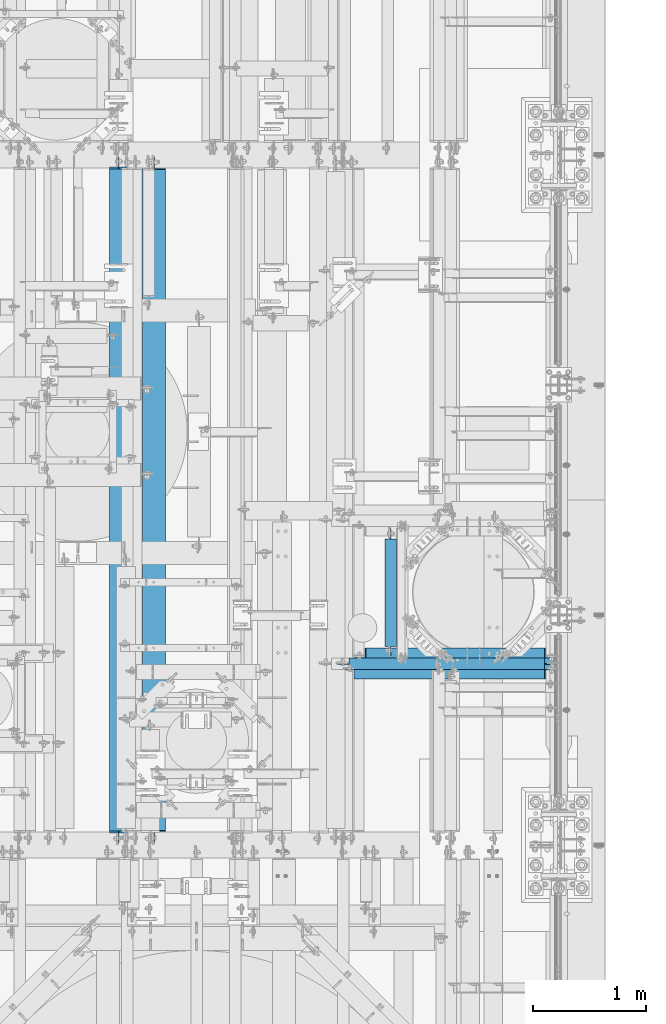
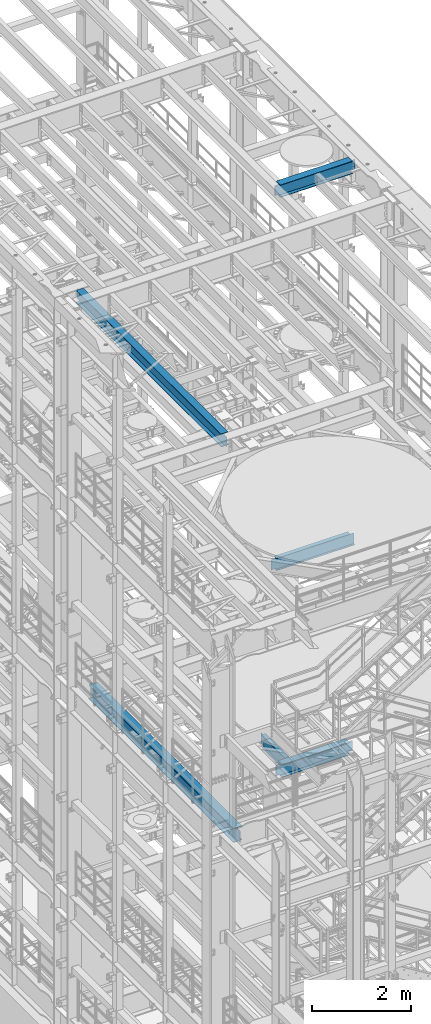
# One storey, part 1029 of 1876: 6 beams, 6 elements without a shape of their own.
"""IFC2X3 building model written with IfcOpenShell, lengths in millimetres."""

from ifc_helpers import new_model, si_unit, frame, origin_with_axes, place, context, subcontext, project, spatial, faceted_brep, material, type_object, element, aggregate, save


model = new_model("IFC2X3")

# Units and contexts
model_context = context("Model", 3, precision=1e-05, world=origin_with_axes())
body_context = subcontext(model_context, "Body", "Model", "MODEL_VIEW")
ifc_project = project(units=[si_unit("LENGTHUNIT", "METRE", prefix="MILLI"), si_unit("AREAUNIT", "SQUARE_METRE"), si_unit("VOLUMEUNIT", "CUBIC_METRE"), si_unit("MASSUNIT", "GRAM", prefix="KILO"), si_unit("TIMEUNIT", "SECOND"), si_unit("PLANEANGLEUNIT", "RADIAN"), si_unit("SOLIDANGLEUNIT", "STERADIAN"), si_unit("THERMODYNAMICTEMPERATUREUNIT", "DEGREE_CELSIUS"), si_unit("LUMINOUSINTENSITYUNIT", "LUMEN")], contexts=[model_context])

# Site, building, storey
site_placement = place(None, origin_with_axes())
site = spatial("IfcSite", under=ifc_project, at=site_placement, CompositionType="ELEMENT")
building_placement = place(site_placement, origin_with_axes())
building = spatial("IfcBuilding", under=site, at=building_placement, Name="Undefined", CompositionType="ELEMENT")
storey_placement = place(building_placement, origin_with_axes())
storey = spatial("IfcBuildingStorey", under=building, at=storey_placement, Name="Undefined", CompositionType="ELEMENT", Elevation=0.0)

# Assembly, beam
assembly_1_placement = place(storey_placement, origin_with_axes())
assembly_1 = element("IfcElementAssembly", 1, at=assembly_1_placement, inside=storey, Name="BEAM", AssemblyPlace="NOTDEFINED", PredefinedType="RIGID_FRAME")
ifc_material = material(Name="STEEL/A992")
beam_type_1 = type_object("IfcBeamType", Name="W12X26", PredefinedType="NOTDEFINED")
beam_1_placement = place(assembly_1_placement, frame((5715.0, 3073.39920043945, 22399.625), z_axis=(0.0, 0.0, 1.0), x_axis=(1.0, 0.0, 0.0)))
beam_1 = element("IfcBeam", 2, at=beam_1_placement, type_object=beam_type_1, material=ifc_material, Name="BEAM", ObjectType="W12X26", context=body_context, shape_type="Brep", body=[
    faceted_brep([(1789.90625, -3.17500000000018, -146.049999999999), (1789.90625, -82.5500000000002, -146.049999999999), (1789.90625, -82.5500000000002, -155.575000000001), (1789.90625, 82.5500000000002, -155.575000000001), (1789.90625, 82.5500000000002, -146.049999999999), (1789.90625, 3.17500000000018, -146.049999999999), (1789.90625, 3.17500000000018, -142.874999809264), (1789.90625, -3.17500000000018, -142.874999809264), (1790.87297992259, 3.17500000000018, -138.014920291218), (1790.87297992259, -3.17500000000018, -138.014920291218), (1793.62599382307, 3.17500000000018, -133.894743823064), (1793.62599382307, -3.17500000000018, -133.894743823064), (1797.74617029122, 3.17500000000018, -131.141729922587), (1797.74617029122, -3.17500000000018, -131.141729922587), (1802.60624980926, 3.17500000000018, -130.174999999999), (1802.60624980926, -3.17500000000018, -130.174999999999), (1885.15625, -3.17500000000018, -130.174999999999), (1885.15625, 3.17500000000018, -130.174999999999), (98.4250000000029, 3.17500000000018, 146.049999999999), (98.4250000000002, 82.5500000000002, 146.049999999999), (1777.20625, 82.5500000000002, 146.049999999999), (1777.20625, 3.17500000000018, 146.049999999999), (98.4250000000002, -3.17500000000018, -142.874999809268), (98.4250000000002, 3.17500000000018, -142.874999809268), (98.4250000000029, 3.17500000000018, -146.049999999999), (98.4250000000002, 82.5500000000002, -146.049999999999), (98.4250000000002, 82.5500000000002, -155.575000000001), (98.4250000000002, -82.5500000000002, -155.575000000001), (98.4250000000002, -82.5500000000002, -146.049999999999), (98.4250000000029, -3.17500000000018, -146.049999999999), (97.4582700774126, -3.17500000000018, -138.014920291222), (97.4582700774126, 3.17500000000018, -138.014920291222), (94.7052561769342, -3.17500000000018, -133.894743823068), (94.7052561769342, 3.17500000000018, -133.894743823068), (90.5850797087805, -3.17500000000018, -131.14172992259), (90.5850797087805, 3.17500000000018, -131.14172992259), (85.725000190735, -3.17500000000018, -130.175000000003), (85.725000190735, 3.17500000000018, -130.175000000003), (15.875, -3.17500000000018, -130.175000000003), (15.875, 3.17500000000018, -130.175000000003), (15.875, -3.17500000000018, 117.474999999999), (15.875, 3.17500000000018, 117.474999999999), (85.725000190735, -3.17500000000018, 117.474999999999), (85.725000190735, 3.17500000000018, 117.474999999999), (90.5850797087805, -3.17500000000018, 118.441729922586), (90.5850797087805, 3.17500000000018, 118.441729922586), (94.7052561769342, -3.17500000000018, 121.194743823064), (94.7052561769342, 3.17500000000018, 121.194743823064), (97.4582700774126, -3.17500000000018, 125.314920291217), (97.4582700774126, 3.17500000000018, 125.314920291217), (98.4250000000002, -3.17500000000018, 130.174999809264), (98.4250000000002, 3.17500000000018, 130.174999809264), (98.4250000000002, -82.5500000000002, 155.575000000001), (98.4250000000002, 82.5500000000002, 155.575000000001), (98.4250000000029, -3.17500000000018, 146.049999999999), (98.4250000000002, -82.5500000000002, 146.049999999999), (1777.20625, -3.17500000000018, 146.049999999999), (1777.20625, -82.5500000000002, 146.049999999999), (1777.20625, -82.5500000000002, 155.575000000001), (1777.20625, 82.5500000000002, 155.575000000001), (1777.20625, -3.17500000000018, 130.174999809267), (1777.20625, 3.17500000000018, 130.174999809267), (1778.17297992259, -3.17500000000018, 125.314920291221), (1778.17297992259, 3.17500000000018, 125.314920291221), (1780.92599382307, -3.17500000000018, 121.194743823067), (1780.92599382307, 3.17500000000018, 121.194743823067), (1785.04617029122, -3.17500000000018, 118.44172992259), (1785.04617029122, 3.17500000000018, 118.44172992259), (1789.90624980926, -3.17500000000018, 117.475000000002), (1789.90624980926, 3.17500000000018, 117.475000000002), (1885.15625, -3.17500000000018, 117.475000000002), (1885.15625, 3.17500000000018, 117.475000000002)], [[[0, 1, 2, 3, 4, 5, 6, 7]], [[7, 6, 8, 9]], [[9, 8, 10, 11]], [[11, 10, 12, 13]], [[13, 12, 14, 15]], [[16, 15, 14, 17]], [[18, 19, 20, 21]], [[22, 23, 24, 25, 26, 27, 28, 29]], [[30, 31, 23, 22]], [[32, 33, 31, 30]], [[34, 35, 33, 32]], [[36, 37, 35, 34]], [[38, 39, 37, 36]], [[40, 41, 39, 38]], [[42, 43, 41, 40]], [[44, 45, 43, 42]], [[46, 47, 45, 44]], [[48, 49, 47, 46]], [[50, 51, 49, 48]], [[52, 53, 19, 18, 51, 50, 54, 55]], [[55, 54, 56, 57]], [[52, 55, 57, 58]], [[53, 52, 58, 59]], [[19, 53, 59, 20]], [[58, 57, 56, 60, 61, 21, 20, 59]], [[62, 63, 61, 60]], [[64, 65, 63, 62]], [[66, 67, 65, 64]], [[68, 69, 67, 66]], [[70, 71, 69, 68]], [[71, 70, 16, 17]], [[12, 10, 8, 6, 5, 24, 23, 31, 33, 35, 37, 39, 41, 43, 45, 47, 49, 51, 18, 21, 61, 63, 65, 67, 69, 71, 17, 14]], [[25, 24, 5, 4]], [[26, 25, 4, 3]], [[27, 26, 3, 2]], [[28, 27, 2, 1]], [[29, 28, 1, 0]], [[70, 68, 66, 64, 62, 60, 56, 54, 50, 48, 46, 44, 42, 40, 38, 36, 34, 32, 30, 22, 29, 0, 7, 9, 11, 13, 15, 16]]]),
])
aggregate(assembly_1, [beam_1])

assembly_2_placement = place(storey_placement, origin_with_axes())
assembly_2 = element("IfcElementAssembly", 3, at=assembly_2_placement, inside=storey, Name="BEAM", AssemblyPlace="NOTDEFINED", PredefinedType="RIGID_FRAME")
beam_2_placement = place(assembly_2_placement, frame((3733.8, 1524.0, 17827.625), z_axis=(0.0, 0.0, 1.0), x_axis=(0.0, 1.0, 0.0)))
beam_2 = element("IfcBeam", 4, at=beam_2_placement, type_object=beam_type_1, material=ifc_material, Name="BEAM", ObjectType="W12X26", context=body_context, shape_type="Brep", body=[
    faceted_brep([(19.8437512414296, -3.17500000000109, -130.175), (19.8437487585795, 3.17499999999927, -130.175), (96.0437824675421, 3.175000000002, -130.175), (96.0437824675423, -3.17499999999745, -130.175), (100.903861985588, 3.175000000002, -131.141729922588), (100.903861985589, -3.17499999999745, -131.141729922588), (105.024038453743, 3.17500000000291, -133.894743823066), (105.024038453744, -3.17499999999654, -133.894743823066), (107.777052354222, 3.17500000000291, -138.01492029122), (107.777052354222, -3.17499999999745, -138.01492029122), (108.743782276811, -3.17499999999654, -142.874999809265), (108.74378227681, 3.17500000000291, -142.874999809265), (108.74375, 3.17500009516311, -146.049999999999), (108.743782276807, 82.5500000000084, -146.05), (108.743782276807, 82.5500000000084, -155.575), (108.743782276814, -82.5500000000029, -155.575), (108.743782276814, -82.5500000000029, -146.05), (108.74375, -3.17499999999995, -146.049999999999), (5969.79375, 82.55, 146.049999999999), (5969.79375, 3.17499999999995, 146.049999999999), (126.20625, 3.17499999999995, 146.049999999999), (126.20625, 82.55, 146.049999999999), (113.506250190735, -3.17499999999995, 111.125000000004), (113.506250190735, 3.17499998562812, 111.125000000004), (19.8437500000002, 3.17499999999995, 111.125000000004), (19.8437500000002, -3.17499999999995, 111.125000000004), (118.36632970878, -3.17499999999995, 112.091729922591), (118.36632970878, 3.17499998547237, 112.091729922591), (122.486506176934, -3.17499999999995, 114.844743823069), (122.486506176934, 3.17499998502694, 114.844743823069), (125.239520077412, -3.17499999999995, 118.964920291222), (125.239520077412, 3.17499998436006, 118.964920291222), (126.20625, -3.17499999999995, 123.824999809269), (126.20625, 3.17499998357312, 123.824999809269), (5969.79375, -82.55, 155.575000000001), (5969.79375, 82.55, 155.575000000001), (126.20625, 82.55, 155.575000000001), (126.20625, -82.55, 155.575000000001), (5969.79375, -82.55, 146.049999999999), (126.20625, -82.55, 146.049999999999), (5969.79375, -3.17499999999995, 146.049999999999), (126.20625, -3.17499999999995, 146.049999999999), (5969.79375, -3.17499999999995, 123.824999809269), (5969.79375, 3.17499999999995, 123.824999809269), (5970.76047992259, -3.17499999999995, 118.964920291222), (5970.76047992259, 3.17499999999995, 118.964920291222), (5973.51349382307, -3.17499999999995, 114.844743823069), (5973.51349382307, 3.17499999999995, 114.844743823069), (5977.63367029122, -3.17499999999995, 112.091729922591), (5977.63367029122, 3.17499999999995, 112.091729922591), (5982.49374980926, -3.17499999999995, 111.125000000004), (5982.49374980926, 3.17499999999995, 111.125000000004), (6076.15625, -3.17499999999995, 111.125000000004), (6076.15625, 3.17499999999995, 111.125000000004), (6076.15625, -3.17499999999995, -130.174999999996), (6076.15625, 3.17499999999995, -130.174999999996), (5999.95624980927, -3.17499999999995, -130.174999999996), (5999.95624980927, 3.17499999999995, -130.174999999996), (5995.09617029122, -3.17499999999995, -131.141729922583), (5995.09617029122, 3.17499999999995, -131.141729922583), (5990.97599382307, -3.17499999999995, -133.894743823061), (5990.97599382307, 3.17499999999995, -133.894743823061), (5988.22297992259, -3.17499999999995, -138.014920291214), (5988.22297992259, 3.17499999999995, -138.014920291214), (5987.25625, -3.17499999999995, -142.874999809261), (5987.25625, 3.17499999999995, -142.874999809261), (5987.25625, -3.17499999999995, -146.049999999999), (5987.25625, -82.55, -146.049999999999), (5987.25625, -82.55, -155.575000000001), (5987.25625, 82.55, -155.575000000001), (5987.25625, 82.55, -146.049999999999), (5987.25625, 3.17499999999995, -146.049999999999)], [[[0, 1, 2, 3]], [[3, 2, 4, 5]], [[5, 4, 6, 7]], [[7, 6, 8, 9]], [[10, 11, 12, 13, 14, 15, 16, 17]], [[9, 8, 11, 10]], [[18, 19, 20, 21]], [[22, 23, 24, 25]], [[26, 27, 23, 22]], [[28, 29, 27, 26]], [[30, 31, 29, 28]], [[32, 33, 31, 30]], [[34, 35, 36, 37]], [[38, 34, 37, 39]], [[40, 38, 39, 41]], [[37, 36, 21, 20, 33, 32, 41, 39]], [[35, 18, 21, 36]], [[34, 38, 40, 42, 43, 19, 18, 35]], [[44, 45, 43, 42]], [[46, 47, 45, 44]], [[48, 49, 47, 46]], [[50, 51, 49, 48]], [[52, 53, 51, 50]], [[53, 52, 54, 55]], [[54, 56, 57, 55]], [[58, 59, 57, 56]], [[60, 61, 59, 58]], [[62, 63, 61, 60]], [[64, 65, 63, 62]], [[66, 67, 68, 69, 70, 71, 65, 64]], [[67, 66, 17, 16]], [[68, 67, 16, 15]], [[69, 68, 15, 14]], [[70, 69, 14, 13]], [[71, 70, 13, 12]], [[6, 4, 2, 1, 24, 23, 27, 29, 31, 33, 20, 19, 43, 45, 47, 49, 51, 53, 55, 57, 59, 61, 63, 65, 71, 12, 11, 8]], [[25, 24, 1, 0]], [[66, 64, 62, 60, 58, 56, 54, 52, 50, 48, 46, 44, 42, 40, 41, 32, 30, 28, 26, 22, 25, 0, 3, 5, 7, 9, 10, 17]]]),
])
aggregate(assembly_2, [beam_2])

assembly_3_placement = place(storey_placement, origin_with_axes())
assembly_3 = element("IfcElementAssembly", 5, at=assembly_3_placement, inside=storey, Name="BEAM", AssemblyPlace="NOTDEFINED", PredefinedType="RIGID_FRAME")
beam_type_2 = type_object("IfcBeamType", Name="W12X16", PredefinedType="NOTDEFINED")
beam_3_placement = place(assembly_3_placement, frame((5651.5, 3124.2, 13157.2), z_axis=(0.0, 0.0, 1.0), x_axis=(1.0, 0.0, 0.0)))
beam_3 = element("IfcBeam", 6, at=beam_3_placement, type_object=beam_type_2, material=ifc_material, Name="BEAM", ObjectType="W12X16", context=body_context, shape_type="Brep", body=[
    faceted_brep([(1840.70625305176, -50.8000000000002, 152.4), (1840.70625305176, -50.8000000000002, 146.049999999999), (1840.70625305176, -3.17500000000018, 146.049999999999), (1840.70625305176, -3.17500000000018, 126.999999809264), (1840.70625305176, 3.17500000000018, 126.999999809264), (1840.70625305176, 3.17500000000018, 146.049999999999), (1840.70625305176, 50.8000000000002, 146.049999999999), (1840.70625305176, 50.8000000000002, 152.4), (1841.67298297434, -3.17500000000018, 122.139920291218), (1841.67298297434, 3.17500000000018, 122.139920291218), (1844.42599687482, -3.17500000000018, 118.019743823064), (1844.42599687482, 3.17500000000018, 118.019743823064), (1848.54617334297, -3.17500000000018, 115.266729922587), (1848.54617334297, 3.17500000000018, 115.266729922587), (1853.40625286102, -3.17500000000018, 114.299999999999), (1853.40625286102, 3.17500000000018, 114.299999999999), (1948.65625, -3.17500000000018, 114.299999999999), (1948.65625, 3.17500000000018, 114.299999999999), (117.475, -50.8000000000002, 152.4), (117.475, 50.8000000000002, 152.4), (117.475, 50.8000000000002, 146.049999999999), (117.475, 3.17500000000018, 146.049999999999), (117.475, 3.17500000000018, 139.699999809265), (117.475, -3.17500000000018, 139.699999809265), (117.475, -3.17500000000018, 146.049999999999), (117.475, -50.8000000000002, 146.049999999999), (116.508270077413, 3.17500000000018, 134.839920291219), (116.508270077413, -3.17500000000018, 134.839920291219), (113.755256176934, 3.17500000000018, 130.719743823065), (113.755256176934, -3.17500000000018, 130.719743823065), (109.635079708781, 3.17500000000018, 127.966729922588), (109.635079708781, -3.17500000000018, 127.966729922588), (104.775000190735, 3.17500000000018, 127.0), (104.775000190735, -3.17500000000018, 127.0), (15.875, 3.17500000000018, 127.000000000001), (15.875, -3.17500000000018, 127.000000000001), (15.8749999999982, 3.17500000000018, -127.0), (15.8749999999982, -3.17500000000018, -127.0), (104.775000190735, 3.17500000000018, -127.0), (104.775000190735, -3.17500000000018, -127.0), (109.635079708781, 3.17500000000018, -127.966729922588), (109.635079708781, -3.17500000000018, -127.966729922588), (113.755256176934, 3.17500000000018, -130.719743823065), (113.755256176934, -3.17500000000018, -130.719743823065), (116.508270077413, 3.17500000000018, -134.839920291219), (116.508270077413, -3.17500000000018, -134.839920291219), (117.475, 3.17500000000018, -139.699999809265), (117.475, -3.17500000000018, -139.699999809265), (1948.65625, 3.17500000000018, -146.049999999999), (1948.65625, 50.8000000000002, -146.049999999999), (117.475, 50.8000000000002, -146.049999999999), (117.475, 3.17500000000018, -146.049999999999), (1948.65625, 50.8000000000002, -152.4), (117.475, 50.8000000000002, -152.4), (1948.65625, -50.8000000000002, -152.4), (117.475, -50.8000000000002, -152.4), (1948.65625, -50.8000000000002, -146.049999999999), (117.475, -50.8000000000002, -146.049999999999), (117.475, -3.17500000000018, -146.049999999999), (1948.65625, -3.17500000000018, -146.049999999999)], [[[0, 1, 2, 3, 4, 5, 6, 7]], [[8, 9, 4, 3]], [[10, 11, 9, 8]], [[12, 13, 11, 10]], [[14, 15, 13, 12]], [[16, 17, 15, 14]], [[18, 19, 20, 21, 22, 23, 24, 25]], [[23, 22, 26, 27]], [[27, 26, 28, 29]], [[29, 28, 30, 31]], [[31, 30, 32, 33]], [[33, 32, 34, 35]], [[35, 34, 36, 37]], [[37, 36, 38, 39]], [[39, 38, 40, 41]], [[41, 40, 42, 43]], [[43, 42, 44, 45]], [[45, 44, 46, 47]], [[48, 49, 50, 51]], [[49, 52, 53, 50]], [[52, 54, 55, 53]], [[54, 56, 57, 55]], [[47, 46, 51, 50, 53, 55, 57, 58]], [[56, 59, 58, 57]], [[12, 10, 8, 3, 2, 24, 23, 27, 29, 31, 33, 35, 37, 39, 41, 43, 45, 47, 58, 59, 16, 14]], [[25, 24, 2, 1]], [[18, 25, 1, 0]], [[19, 18, 0, 7]], [[20, 19, 7, 6]], [[21, 20, 6, 5]], [[48, 51, 46, 44, 42, 40, 38, 36, 34, 32, 30, 28, 26, 22, 21, 5, 4, 9, 11, 13, 15, 17]], [[59, 56, 54, 52, 49, 48, 17, 16]]]),
])
aggregate(assembly_3, [beam_3])

assembly_4_placement = place(storey_placement, origin_with_axes())
assembly_4 = element("IfcElementAssembly", 7, at=assembly_4_placement, inside=storey, Name="BEAM", AssemblyPlace="NOTDEFINED", PredefinedType="RIGID_FRAME")
beam_4_placement = place(assembly_4_placement, frame((6134.1, 3181.35, 8001.0), z_axis=(0.0, 0.0, 1.0), x_axis=(0.0, 1.0, 0.0)))
beam_4 = element("IfcBeam", 8, at=beam_4_placement, type_object=beam_type_2, material=ifc_material, Name="BEAM", ObjectType="W12X16", context=body_context, shape_type="Brep", body=[
    faceted_brep([(17.4625000000005, -3.17500000000018, -126.999999999999), (17.4625000000005, 3.17500000000018, -126.999999999999), (100.012500190734, 3.17500000000018, -126.999999999999), (100.012500190734, -3.17500000000018, -126.999999999999), (104.87257970878, 3.17500000000018, -127.966729922587), (104.87257970878, -3.17500000000018, -127.966729922587), (108.992756176934, 3.17500000000018, -130.719743823065), (108.992756176934, -3.17500000000018, -130.719743823065), (111.745770077412, 3.17500000000018, -134.839920291219), (111.745770077412, -3.17500000000018, -134.839920291219), (112.7125, -3.17500000000018, -139.699999809264), (112.7125, 3.17500000000018, -139.699999809264), (112.712500000001, 3.17500000000018, -146.049999999999), (112.7125, 50.8000000000002, -146.05), (112.7125, 50.8000000000002, -152.4), (112.7125, -50.8000000000002, -152.4), (112.7125, -50.8000000000002, -146.05), (112.712500000001, -3.17500000000018, -146.049999999999), (1044.575, 50.8000000000002, 146.05), (1044.575, 3.17500000000018, 146.05), (96.8374999999996, 3.17500000000018, 146.05), (96.8374999999996, 50.8000000000002, 146.05), (84.1375001907345, -3.17500000000018, 127.000000000001), (84.1375001907345, 3.17500000000018, 127.000000000001), (17.4625000000005, 3.17500000000018, 127.000000000001), (17.4625000000005, -3.17500000000018, 127.000000000001), (88.99757970878, -3.17500000000018, 127.966729922588), (88.99757970878, 3.17500000000018, 127.966729922588), (93.1177561769337, -3.17500000000018, 130.719743823067), (93.1177561769337, 3.17500000000018, 130.719743823067), (95.8707700774116, -3.17500000000018, 134.839920291221), (95.8707700774116, 3.17500000000018, 134.839920291221), (96.8374999999996, -3.17500000000018, 139.699999809266), (96.8374999999996, 3.17500000000018, 139.699999809266), (1044.575, -50.8000000000002, 152.4), (1044.575, 50.8000000000002, 152.4), (96.8374999999996, 50.8000000000002, 152.4), (96.8374999999996, -50.8000000000002, 152.4), (1044.575, -50.8000000000002, 146.05), (96.8374999999996, -50.8000000000002, 146.05), (1044.575, -3.17500000000018, 146.05), (96.8374999999996, -3.17500000000018, 146.05), (1044.575, -3.17500000000018, 139.699999809266), (1044.575, 3.17500000000018, 139.699999809266), (1045.54172992259, -3.17500000000018, 134.839920291221), (1045.54172992259, 3.17500000000018, 134.839920291221), (1048.29474382306, -3.17500000000018, 130.719743823067), (1048.29474382306, 3.17500000000018, 130.719743823067), (1052.41492029122, -3.17500000000018, 127.966729922588), (1052.41492029122, 3.17500000000018, 127.966729922588), (1057.27499980926, -3.17500000000018, 127.000000000001), (1057.27499980926, 3.17500000000018, 127.000000000001), (1139.825, -3.17500000000018, 127.000000000001), (1139.825, 3.17500000000018, 127.000000000001), (1139.825, -3.17500000000018, -126.999999999999), (1139.825, 3.17500000000018, -126.999999999999), (1057.27499980926, -3.17500000000018, -126.999999999999), (1057.27499980926, 3.17500000000018, -126.999999999999), (1052.41492029122, -3.17500000000018, -127.966729922587), (1052.41492029122, 3.17500000000018, -127.966729922587), (1048.29474382306, -3.17500000000018, -130.719743823065), (1048.29474382306, 3.17500000000018, -130.719743823065), (1045.54172992259, -3.17500000000018, -134.839920291219), (1045.54172992259, 3.17500000000018, -134.839920291219), (1044.575, -3.17500000000018, -139.699999809264), (1044.575, 3.17500000000018, -139.699999809264), (1044.575, -3.17500000000018, -146.05), (1044.575, -50.8000000000002, -146.05), (1044.575, -50.8000000000002, -152.4), (1044.575, 50.8000000000002, -152.4), (1044.575, 50.8000000000002, -146.05), (1044.575, 3.17500000000018, -146.05)], [[[0, 1, 2, 3]], [[3, 2, 4, 5]], [[5, 4, 6, 7]], [[7, 6, 8, 9]], [[10, 11, 12, 13, 14, 15, 16, 17]], [[9, 8, 11, 10]], [[18, 19, 20, 21]], [[22, 23, 24, 25]], [[26, 27, 23, 22]], [[28, 29, 27, 26]], [[30, 31, 29, 28]], [[32, 33, 31, 30]], [[34, 35, 36, 37]], [[38, 34, 37, 39]], [[40, 38, 39, 41]], [[37, 36, 21, 20, 33, 32, 41, 39]], [[35, 18, 21, 36]], [[34, 38, 40, 42, 43, 19, 18, 35]], [[44, 45, 43, 42]], [[46, 47, 45, 44]], [[48, 49, 47, 46]], [[50, 51, 49, 48]], [[52, 53, 51, 50]], [[53, 52, 54, 55]], [[54, 56, 57, 55]], [[58, 59, 57, 56]], [[60, 61, 59, 58]], [[62, 63, 61, 60]], [[64, 65, 63, 62]], [[66, 67, 68, 69, 70, 71, 65, 64]], [[67, 66, 17, 16]], [[68, 67, 16, 15]], [[69, 68, 15, 14]], [[70, 69, 14, 13]], [[71, 70, 13, 12]], [[6, 4, 2, 1, 24, 23, 27, 29, 31, 33, 20, 19, 43, 45, 47, 49, 51, 53, 55, 57, 59, 61, 63, 65, 71, 12, 11, 8]], [[25, 24, 1, 0]], [[66, 64, 62, 60, 58, 56, 54, 52, 50, 48, 46, 44, 42, 40, 41, 32, 30, 28, 26, 22, 25, 0, 3, 5, 7, 9, 10, 17]]]),
])
aggregate(assembly_4, [beam_4])

assembly_5_placement = place(storey_placement, origin_with_axes())
assembly_5 = element("IfcElementAssembly", 9, at=assembly_5_placement, inside=storey, Name="BEAM", AssemblyPlace="NOTDEFINED", PredefinedType="RIGID_FRAME")
beam_type_3 = type_object("IfcBeamType", Name="W12X30", PredefinedType="NOTDEFINED")
beam_5_placement = place(assembly_5_placement, frame((5645.15, 3182.9375, 7996.2375), z_axis=(0.0, 0.0, 1.0), x_axis=(1.0, 0.0, 0.0)))
beam_5 = element("IfcBeam", 10, at=beam_5_placement, type_object=beam_type_3, material=ifc_material, Name="BEAM", ObjectType="W12X30", context=body_context, shape_type="Brep", body=[
    faceted_brep([(169.068749999999, -3.17500000000018, -131.7625), (169.068749999999, 3.17500000000018, -131.7625), (251.618750190735, 3.17500000000018, -131.7625), (251.618750190735, -3.17500000000018, -131.7625), (256.478829708781, 3.17500000000018, -132.729229922587), (256.478829708781, -3.17500000000018, -132.729229922587), (260.599006176934, 3.17500000000018, -135.482243823066), (260.599006176934, -3.17500000000018, -135.482243823066), (263.352020077413, 3.17500000000018, -139.602420291219), (263.352020077413, -3.17500000000018, -139.602420291219), (264.31875, -3.17500000000018, -144.462499809265), (264.31875, 3.17500000000018, -144.462499809265), (264.31875, 3.17500000000018, -146.05), (264.31875, 82.5500000000002, -146.05), (264.31875, 82.5500000000002, -157.1625), (264.31875, -82.5500000000002, -157.1625), (264.31875, -82.5500000000002, -146.05), (264.31875, -3.17500000000018, -146.05), (1847.05625, 82.5500000000002, 146.05), (1847.05625, 3.17500000000018, 146.05), (270.668750000001, 3.17500000000018, 146.05), (270.668750000001, 82.5500000000002, 146.05), (257.968750190736, -3.17500000000018, 125.4125), (257.968750190736, 3.17500000000018, 125.4125), (169.068749999999, 3.17500000000018, 125.4125), (169.068749999999, -3.17500000000018, 125.4125), (262.828829708781, -3.17500000000018, 126.379229922588), (262.828829708781, 3.17500000000018, 126.379229922588), (266.949006176935, -3.17500000000018, 129.132243823066), (266.949006176935, 3.17500000000018, 129.132243823066), (269.702020077413, -3.17500000000018, 133.25242029122), (269.702020077413, 3.17500000000018, 133.25242029122), (270.668750000001, -3.17500000000018, 138.112499809266), (270.668750000001, 3.17500000000018, 138.112499809266), (1847.05625, -82.5500000000002, 157.1625), (1847.05625, 82.5500000000002, 157.1625), (270.668750000001, 82.5500000000002, 157.1625), (270.668750000001, -82.5500000000002, 157.1625), (1847.05625, -82.5500000000002, 146.05), (270.668750000001, -82.5500000000002, 146.05), (1847.05625, -3.17500000000018, 146.05), (270.668750000001, -3.17500000000018, 146.05), (1847.05625, -3.17500000000018, 131.762499809264), (1847.05625, 3.17500000000018, 131.762499809264), (1848.02297992259, -3.17500000000018, 126.902420291219), (1848.02297992259, 3.17500000000018, 126.902420291219), (1850.77599382307, -3.17500000000018, 122.782243823065), (1850.77599382307, 3.17500000000018, 122.782243823065), (1854.89617029122, -3.17500000000018, 120.029229922587), (1854.89617029122, 3.17500000000018, 120.029229922587), (1859.75624980926, -3.17500000000018, 119.062499999999), (1859.75624980926, 3.17500000000018, 119.062499999999), (1955.00625, -3.17500000000018, 119.062499999999), (1955.00625, 3.17500000000018, 119.062499999999), (1955.00625, -3.17500000000018, -131.762500000001), (1955.00625, 3.17500000000018, -131.762500000001), (1872.45624980926, -3.17500000000018, -131.762500000001), (1872.45624980926, 3.17500000000018, -131.762500000001), (1867.59617029122, -3.17500000000018, -132.729229922588), (1867.59617029122, 3.17500000000018, -132.729229922588), (1863.47599382307, -3.17500000000018, -135.482243823067), (1863.47599382307, 3.17500000000018, -135.482243823067), (1860.72297992259, -3.17500000000018, -139.60242029122), (1860.72297992259, 3.17500000000018, -139.60242029122), (1859.75625, -3.17500000000018, -144.462499809266), (1859.75625, 3.17500000000018, -144.462499809266), (1859.75625, -3.17500000000018, -146.05), (1859.75625, -82.5500000000002, -146.05), (1859.75625, -82.5500000000002, -157.1625), (1859.75625, 82.5500000000002, -157.1625), (1859.75625, 82.5500000000002, -146.05), (1859.75625, 3.17500000000018, -146.05)], [[[0, 1, 2, 3]], [[3, 2, 4, 5]], [[5, 4, 6, 7]], [[7, 6, 8, 9]], [[10, 11, 12, 13, 14, 15, 16, 17]], [[9, 8, 11, 10]], [[18, 19, 20, 21]], [[22, 23, 24, 25]], [[26, 27, 23, 22]], [[28, 29, 27, 26]], [[30, 31, 29, 28]], [[32, 33, 31, 30]], [[34, 35, 36, 37]], [[38, 34, 37, 39]], [[40, 38, 39, 41]], [[37, 36, 21, 20, 33, 32, 41, 39]], [[35, 18, 21, 36]], [[34, 38, 40, 42, 43, 19, 18, 35]], [[44, 45, 43, 42]], [[46, 47, 45, 44]], [[48, 49, 47, 46]], [[50, 51, 49, 48]], [[52, 53, 51, 50]], [[53, 52, 54, 55]], [[54, 56, 57, 55]], [[58, 59, 57, 56]], [[60, 61, 59, 58]], [[62, 63, 61, 60]], [[64, 65, 63, 62]], [[66, 67, 68, 69, 70, 71, 65, 64]], [[67, 66, 17, 16]], [[68, 67, 16, 15]], [[69, 68, 15, 14]], [[70, 69, 14, 13]], [[71, 70, 13, 12]], [[6, 4, 2, 1, 24, 23, 27, 29, 31, 33, 20, 19, 43, 45, 47, 49, 51, 53, 55, 57, 59, 61, 63, 65, 71, 12, 11, 8]], [[25, 24, 1, 0]], [[66, 64, 62, 60, 58, 56, 54, 52, 50, 48, 46, 44, 42, 40, 41, 32, 30, 28, 26, 22, 25, 0, 3, 5, 7, 9, 10, 17]]]),
])
aggregate(assembly_5, [beam_5])

assembly_6_placement = place(storey_placement, origin_with_axes())
assembly_6 = element("IfcElementAssembly", 11, at=assembly_6_placement, inside=storey, Name="BEAM", AssemblyPlace="NOTDEFINED", PredefinedType="RIGID_FRAME")
beam_type_4 = type_object("IfcBeamType", Name="W14X48", PredefinedType="NOTDEFINED")
beam_6_placement = place(assembly_6_placement, frame((4044.94962964162, 1524.11878769825, 7978.775), z_axis=(0.0, 0.0, 1.0), x_axis=(0.0, 1.0, 0.0)))
beam_6 = element("IfcBeam", 12, at=beam_6_placement, type_object=beam_type_4, material=ifc_material, Name="BEAM", ObjectType="W14X48", context=body_context, shape_type="Brep", body=[
    faceted_brep([(19.7249623017458, -3.96875, -149.225000000001), (19.7249623017458, 3.96875, -149.225000000001), (108.624962492481, 3.96875, -149.225000000001), (108.624962492481, -3.96875, -149.225000000001), (113.485042010527, 3.96875, -150.191729922589), (113.485042010527, -3.96875, -150.191729922589), (117.60521847868, 3.96875, -152.944743823067), (117.60521847868, -3.96875, -152.944743823067), (120.358232379159, 3.96875, -157.064920291221), (120.358232379159, -3.96875, -157.064920291221), (121.324962301746, -101.6, -161.924999809266), (121.324962301746, 101.6, -161.924999809266), (121.324962301746, 101.6, -174.625), (121.324962301746, -101.6, -174.625), (120.693415573256, -101.6, -158.75), (120.693415573256, -3.96875, -158.75), (120.693415573256, 3.96875, -158.75), (120.693415573256, 101.6, -158.75), (5968.08746230175, 101.6, 158.75), (5968.08746230175, 3.96875, 158.75), (127.674962301747, 3.96875, 158.75), (127.674962301747, 101.6, 158.75), (114.974962492481, -3.96875, 136.524999999999), (114.974962492481, 3.96875, 136.524999999999), (19.7249623017458, 3.96875, 136.524999999999), (19.7249623017458, -3.96875, 136.524999999999), (119.835042010527, -3.96875, 137.491729922586), (119.835042010527, 3.96875, 137.491729922586), (123.955218478681, -3.96875, 140.244743823065), (123.955218478681, 3.96875, 140.244743823065), (126.708232379159, -3.96875, 144.364920291218), (126.708232379159, 3.96875, 144.364920291218), (127.674962301747, -3.96875, 149.224999809264), (127.674962301747, 3.96875, 149.224999809264), (5968.08746230175, -101.6, 174.625), (5968.08746230175, 101.6, 174.625), (127.674962301747, 101.6, 174.625), (127.674962301747, -101.6, 174.625), (5968.08746230175, -101.6, 158.75), (127.674962301747, -101.6, 158.75), (5968.08746230175, -3.96875, 158.75), (127.674962301747, -3.96875, 158.75), (5968.08746230175, -3.96875, 149.224999809264), (5968.08746230175, 3.96875, 149.224999809264), (5969.05419222434, -3.96875, 144.364920291218), (5969.05419222434, 3.96875, 144.364920291218), (5971.80720612481, -3.96875, 140.244743823065), (5971.80720612481, 3.96875, 140.244743823065), (5975.92738259297, -3.96875, 137.491729922586), (5975.92738259297, 3.96875, 137.491729922586), (5980.78746211101, -3.96875, 136.524999999999), (5980.78746211101, 3.96875, 136.524999999999), (6076.03746230175, -3.96875, 136.524999999999), (6076.03746230175, 3.96875, 136.524999999999), (6076.03746230175, -3.96875, -149.225000000001), (6076.03746230175, 3.96875, -149.225000000001), (5987.13746211101, -3.96875, -149.225000000001), (5987.13746211101, 3.96875, -149.225000000001), (5982.27738259297, -3.96875, -150.191729922589), (5982.27738259297, 3.96875, -150.191729922589), (5978.15720612482, -3.96875, -152.944743823067), (5978.15720612482, 3.96875, -152.944743823067), (5975.40419222434, -3.96875, -157.064920291221), (5975.40419222434, 3.96875, -157.064920291221), (5975.06900903024, -3.96875, -158.75), (5975.06900903024, -101.6, -158.75), (5974.43746230175, -101.6, -161.924999809266), (5974.43746230175, 101.6, -161.924999809266), (5975.06900903024, 101.6, -158.75), (5975.06900903024, 3.96875, -158.75), (5974.43746230175, -101.6, -174.625), (5974.43746230175, 101.6, -174.625)], [[[0, 1, 2, 3]], [[3, 2, 4, 5]], [[5, 4, 6, 7]], [[7, 6, 8, 9]], [[10, 11, 12, 13]], [[14, 15, 9, 8, 16, 17, 11, 10]], [[18, 19, 20, 21]], [[22, 23, 24, 25]], [[26, 27, 23, 22]], [[28, 29, 27, 26]], [[30, 31, 29, 28]], [[32, 33, 31, 30]], [[34, 35, 36, 37]], [[38, 34, 37, 39]], [[40, 38, 39, 41]], [[37, 36, 21, 20, 33, 32, 41, 39]], [[35, 18, 21, 36]], [[34, 38, 40, 42, 43, 19, 18, 35]], [[44, 45, 43, 42]], [[46, 47, 45, 44]], [[48, 49, 47, 46]], [[50, 51, 49, 48]], [[52, 53, 51, 50]], [[53, 52, 54, 55]], [[54, 56, 57, 55]], [[58, 59, 57, 56]], [[60, 61, 59, 58]], [[62, 63, 61, 60]], [[64, 65, 66, 67, 68, 69, 63, 62]], [[70, 71, 67, 66]], [[71, 70, 13, 12]], [[68, 67, 71, 12, 11, 17]], [[69, 68, 17, 16]], [[6, 4, 2, 1, 24, 23, 27, 29, 31, 33, 20, 19, 43, 45, 47, 49, 51, 53, 55, 57, 59, 61, 63, 69, 16, 8]], [[25, 24, 1, 0]], [[64, 62, 60, 58, 56, 54, 52, 50, 48, 46, 44, 42, 40, 41, 32, 30, 28, 26, 22, 25, 0, 3, 5, 7, 9, 15]], [[65, 64, 15, 14]], [[70, 66, 65, 14, 10, 13]]]),
])
aggregate(assembly_6, [beam_6])

save(model, "model.ifc")
